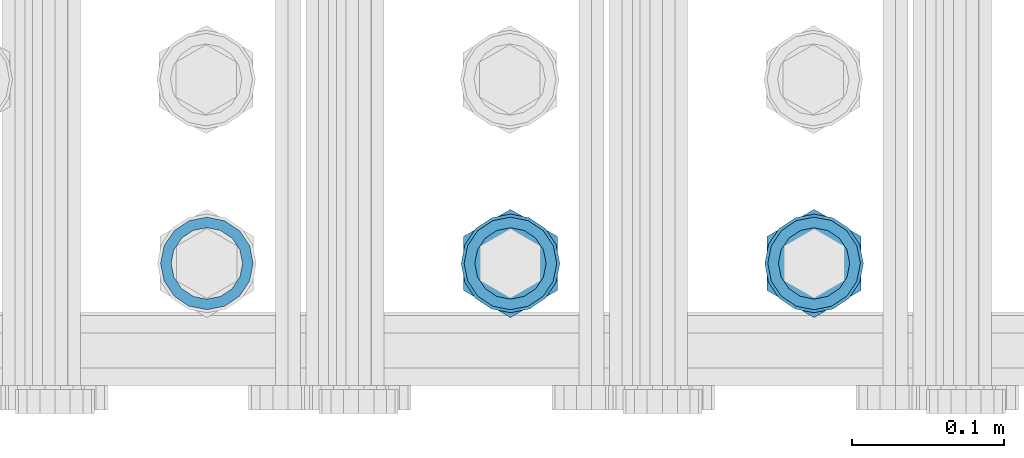
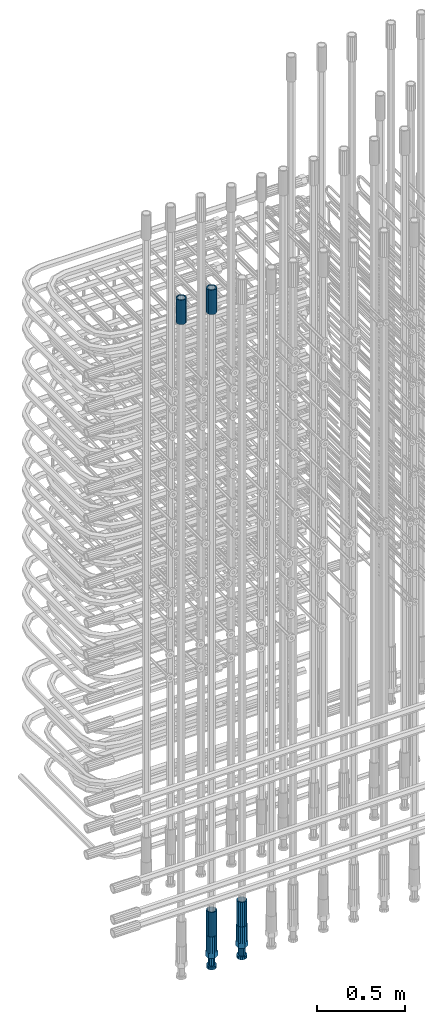
# One storey, part 35 of 177: 6 beams.
"""IFC2X3 building model written with IfcOpenShell, lengths in millimetres."""

from ifc_helpers import new_model, si_unit, frame, origin_with_axes, place, context, subcontext, project, spatial, faceted_brep, material, type_object, element, save


model = new_model("IFC2X3")

# Units and contexts
model_context_1 = context("Model", 3, precision=1e-05, world=origin_with_axes())
model_context_2 = context("Model", 3, precision=1e-05, world=origin_with_axes())
body_context = subcontext(model_context_2, "Body", "Model", "MODEL_VIEW")
ifc_project = project(units=[si_unit("LENGTHUNIT", "METRE", prefix="MILLI"), si_unit("AREAUNIT", "SQUARE_METRE"), si_unit("VOLUMEUNIT", "CUBIC_METRE"), si_unit("MASSUNIT", "GRAM", prefix="KILO"), si_unit("TIMEUNIT", "SECOND"), si_unit("PLANEANGLEUNIT", "RADIAN"), si_unit("SOLIDANGLEUNIT", "STERADIAN"), si_unit("THERMODYNAMICTEMPERATUREUNIT", "DEGREE_CELSIUS"), si_unit("LUMINOUSINTENSITYUNIT", "LUMEN")], contexts=[model_context_1])

# Site, building, storey
site_placement = place(None, origin_with_axes())
site = spatial("IfcSite", under=ifc_project, at=site_placement, CompositionType="ELEMENT")
building_placement = place(site_placement, origin_with_axes())
building = spatial("IfcBuilding", under=site, at=building_placement, Name="Undefined", CompositionType="ELEMENT")
storey_placement = place(building_placement, origin_with_axes())
storey = spatial("IfcBuildingStorey", under=building, at=storey_placement, Name="Undefined", CompositionType="ELEMENT", Elevation=0.0)

# Beams
ifc_material = material(Name="STEEL/S275")
beam_type_1 = type_object("IfcBeamType", PredefinedType="NOTDEFINED")
beam_1_placement = place(storey_placement, frame((2030236.00256267, 6205156.40847529, 22659.9858194828), z_axis=(1.0, 0.0, 0.0), x_axis=(0.0, 0.0, 1.0)))
element("IfcBeam", 1, at=beam_1_placement, inside=storey, type_object=beam_type_1, material=ifc_material, Name="AG40N", context=body_context, shape_type="Brep", body=[
    faceted_brep([(0.0, -23.5000000001164, -9.31322574615479e-10), (0.0, -21.7111690140155, 8.99306066054851), (170.0, -21.7111690140155, 8.99306066054851), (170.0, -23.5, 0.0), (0.0, -16.6170093578839, 16.6170093575493), (170.0, -16.6170093578839, 16.6170093575493), (0.0, -8.99306066057943, 21.7111690137535), (170.0, -8.99306066057943, 21.7111690137535), (0.0, 1.16415321826935e-10, 23.5), (170.0, 0.0, 23.5), (0.0, 8.99306066057943, 21.7111690137535), (170.0, 8.99306066057943, 21.7111690137535), (0.0, 16.6170093578839, 16.6170093575493), (170.0, 16.6170093578839, 16.6170093575493), (0.0, 21.7111690140155, 8.99306066054851), (170.0, 21.7111690140155, 8.99306066054851), (0.0, 23.5000000001164, -9.31322574615479e-10), (170.0, 23.5, 0.0), (0.0, 21.7111690140155, -8.99306066054851), (170.0, 21.7111690140155, -8.99306066054851), (0.0, 16.6170093578839, -16.6170093575493), (170.0, 16.6170093578839, -16.6170093575493), (0.0, 8.99306066057943, -21.7111690137535), (170.0, 8.99306066057943, -21.7111690137535), (0.0, 1.16415321826935e-10, -23.5000000009313), (170.0, 0.0, -23.5), (0.0, -8.99306066057943, -21.7111690137535), (170.0, -8.99306066057943, -21.7111690137535), (0.0, -16.6170093578839, -16.6170093575493), (170.0, -16.6170093578839, -16.6170093575493), (0.0, -21.7111690140155, -8.99306066054851), (170.0, -21.7111690140155, -8.99306066054851), (0.0, -30.5, 0.0), (0.0, -28.1783257415937, -11.6718446873128), (170.0, -28.1783257415937, -11.6718446873128), (170.0, -30.5, 0.0), (0.0, -21.5667568261888, -21.5667568258941), (170.0, -21.5667568261888, -21.5667568258941), (0.0, -11.6718446871346, -28.1783257415518), (170.0, -11.6718446871346, -28.1783257415518), (0.0, 0.0, -30.5), (170.0, 0.0, -30.5), (0.0, 11.6718446871346, -28.1783257415518), (170.0, 11.6718446871346, -28.1783257415518), (0.0, 21.5667568261888, -21.5667568258941), (170.0, 21.5667568261888, -21.5667568258941), (0.0, 28.1783257415937, -11.6718446873128), (170.0, 28.1783257415937, -11.6718446873128), (0.0, 30.5, 0.0), (170.0, 30.5, 0.0), (0.0, 28.1783257415937, 11.6718446873128), (170.0, 28.1783257415937, 11.6718446873128), (0.0, 21.5667568261888, 21.5667568258941), (170.0, 21.5667568261888, 21.5667568258941), (0.0, 11.6718446871346, 28.1783257415518), (170.0, 11.6718446871346, 28.1783257415518), (0.0, 0.0, 30.5), (170.0, 0.0, 30.5), (0.0, -11.6718446871346, 28.1783257415518), (170.0, -11.6718446871346, 28.1783257415518), (0.0, -21.5667568261888, 21.5667568258941), (170.0, -21.5667568261888, 21.5667568258941), (0.0, -28.1783257415937, 11.6718446873128), (170.0, -28.1783257415937, 11.6718446873128)], [[[0, 1, 2, 3]], [[1, 4, 5, 2]], [[4, 6, 7, 5]], [[6, 8, 9, 7]], [[8, 10, 11, 9]], [[10, 12, 13, 11]], [[12, 14, 15, 13]], [[14, 16, 17, 15]], [[16, 18, 19, 17]], [[18, 20, 21, 19]], [[20, 22, 23, 21]], [[22, 24, 25, 23]], [[24, 26, 27, 25]], [[26, 28, 29, 27]], [[28, 30, 31, 29]], [[30, 0, 3, 31]], [[32, 33, 34, 35]], [[33, 36, 37, 34]], [[36, 38, 39, 37]], [[38, 40, 41, 39]], [[40, 42, 43, 41]], [[42, 44, 45, 43]], [[44, 46, 47, 45]], [[46, 48, 49, 47]], [[48, 50, 51, 49]], [[50, 52, 53, 51]], [[52, 54, 55, 53]], [[54, 56, 57, 55]], [[56, 58, 59, 57]], [[58, 60, 61, 59]], [[60, 62, 63, 61]], [[62, 32, 35, 63]], [[37, 39, 41, 43, 45, 47, 49, 51, 53, 55, 57, 59, 61, 63, 35, 34], [5, 7, 9, 11, 13, 15, 17, 19, 21, 23, 25, 27, 29, 31, 3, 2]], [[62, 60, 58, 56, 54, 52, 50, 48, 46, 44, 42, 40, 38, 36, 33, 32], [30, 28, 26, 24, 22, 20, 18, 16, 14, 12, 10, 8, 6, 4, 1, 0]]]),
])
beam_2_placement = place(storey_placement, frame((2030436.00256268, 6205156.4084753, 18490.9668004282), z_axis=(-1.0, 0.0, 0.0), x_axis=(0.0, 0.0, -1.0)))
element("IfcBeam", 2, at=beam_2_placement, inside=storey, type_object=beam_type_1, material=ifc_material, Name="AG40N", context=body_context, shape_type="Brep", body=[
    faceted_brep([(0.0, -23.5000000001164, -9.31322574615479e-10), (0.0, -21.7111690140155, 8.99306066054851), (170.0, -21.7111690140155, 8.99306066054851), (170.0, -23.5, 0.0), (0.0, -16.6170093578839, 16.6170093575493), (170.0, -16.6170093578839, 16.6170093575493), (0.0, -8.99306066057943, 21.7111690137535), (170.0, -8.99306066057943, 21.7111690137535), (0.0, 1.16415321826935e-10, 23.5), (170.0, 0.0, 23.5), (0.0, 8.99306066057943, 21.7111690137535), (170.0, 8.99306066057943, 21.7111690137535), (0.0, 16.6170093578839, 16.6170093575493), (170.0, 16.6170093578839, 16.6170093575493), (0.0, 21.7111690140155, 8.99306066054851), (170.0, 21.7111690140155, 8.99306066054851), (0.0, 23.5000000001164, -9.31322574615479e-10), (170.0, 23.5, 0.0), (0.0, 21.7111690140155, -8.99306066054851), (170.0, 21.7111690140155, -8.99306066054851), (0.0, 16.6170093578839, -16.6170093575493), (170.0, 16.6170093578839, -16.6170093575493), (0.0, 8.99306066057943, -21.7111690137535), (170.0, 8.99306066057943, -21.7111690137535), (0.0, 1.16415321826935e-10, -23.5000000009313), (170.0, 0.0, -23.5), (0.0, -8.99306066057943, -21.7111690137535), (170.0, -8.99306066057943, -21.7111690137535), (0.0, -16.6170093578839, -16.6170093575493), (170.0, -16.6170093578839, -16.6170093575493), (0.0, -21.7111690140155, -8.99306066054851), (170.0, -21.7111690140155, -8.99306066054851), (0.0, -30.5, 0.0), (0.0, -28.1783257415937, -11.6718446873128), (170.0, -28.1783257415937, -11.6718446873128), (170.0, -30.5, 0.0), (0.0, -21.5667568261888, -21.5667568258941), (170.0, -21.5667568261888, -21.5667568258941), (0.0, -11.6718446871346, -28.1783257415518), (170.0, -11.6718446871346, -28.1783257415518), (0.0, 0.0, -30.5), (170.0, 0.0, -30.5), (0.0, 11.6718446871346, -28.1783257415518), (170.0, 11.6718446871346, -28.1783257415518), (0.0, 21.5667568261888, -21.5667568258941), (170.0, 21.5667568261888, -21.5667568258941), (0.0, 28.1783257415937, -11.6718446873128), (170.0, 28.1783257415937, -11.6718446873128), (0.0, 30.5, 0.0), (170.0, 30.5, 0.0), (0.0, 28.1783257415937, 11.6718446873128), (170.0, 28.1783257415937, 11.6718446873128), (0.0, 21.5667568261888, 21.5667568258941), (170.0, 21.5667568261888, 21.5667568258941), (0.0, 11.6718446871346, 28.1783257415518), (170.0, 11.6718446871346, 28.1783257415518), (0.0, 0.0, 30.5), (170.0, 0.0, 30.5), (0.0, -11.6718446871346, 28.1783257415518), (170.0, -11.6718446871346, 28.1783257415518), (0.0, -21.5667568261888, 21.5667568258941), (170.0, -21.5667568261888, 21.5667568258941), (0.0, -28.1783257415937, 11.6718446873128), (170.0, -28.1783257415937, 11.6718446873128)], [[[0, 1, 2, 3]], [[1, 4, 5, 2]], [[4, 6, 7, 5]], [[6, 8, 9, 7]], [[8, 10, 11, 9]], [[10, 12, 13, 11]], [[12, 14, 15, 13]], [[14, 16, 17, 15]], [[16, 18, 19, 17]], [[18, 20, 21, 19]], [[20, 22, 23, 21]], [[22, 24, 25, 23]], [[24, 26, 27, 25]], [[26, 28, 29, 27]], [[28, 30, 31, 29]], [[30, 0, 3, 31]], [[32, 33, 34, 35]], [[33, 36, 37, 34]], [[36, 38, 39, 37]], [[38, 40, 41, 39]], [[40, 42, 43, 41]], [[42, 44, 45, 43]], [[44, 46, 47, 45]], [[46, 48, 49, 47]], [[48, 50, 51, 49]], [[50, 52, 53, 51]], [[52, 54, 55, 53]], [[54, 56, 57, 55]], [[56, 58, 59, 57]], [[58, 60, 61, 59]], [[60, 62, 63, 61]], [[62, 32, 35, 63]], [[37, 39, 41, 43, 45, 47, 49, 51, 53, 55, 57, 59, 61, 63, 35, 34], [5, 7, 9, 11, 13, 15, 17, 19, 21, 23, 25, 27, 29, 31, 3, 2]], [[62, 60, 58, 56, 54, 52, 50, 48, 46, 44, 42, 40, 38, 36, 33, 32], [30, 28, 26, 24, 22, 20, 18, 16, 14, 12, 10, 8, 6, 4, 1, 0]]]),
])
beam_3_placement = place(storey_placement, frame((2030436.00256267, 6205156.40847529, 22659.9858194828), z_axis=(1.0, 0.0, 0.0), x_axis=(0.0, 0.0, 1.0)))
element("IfcBeam", 3, at=beam_3_placement, inside=storey, type_object=beam_type_1, material=ifc_material, Name="AG40N", context=body_context, shape_type="Brep", body=[
    faceted_brep([(0.0, -23.5000000001164, -9.31322574615479e-10), (0.0, -21.7111690140155, 8.99306066054851), (170.0, -21.7111690140155, 8.99306066054851), (170.0, -23.5, 0.0), (0.0, -16.6170093578839, 16.6170093575493), (170.0, -16.6170093578839, 16.6170093575493), (0.0, -8.99306066057943, 21.7111690137535), (170.0, -8.99306066057943, 21.7111690137535), (0.0, 1.16415321826935e-10, 23.5), (170.0, 0.0, 23.5), (0.0, 8.99306066057943, 21.7111690137535), (170.0, 8.99306066057943, 21.7111690137535), (0.0, 16.6170093578839, 16.6170093575493), (170.0, 16.6170093578839, 16.6170093575493), (0.0, 21.7111690140155, 8.99306066054851), (170.0, 21.7111690140155, 8.99306066054851), (0.0, 23.5000000001164, -9.31322574615479e-10), (170.0, 23.5, 0.0), (0.0, 21.7111690140155, -8.99306066054851), (170.0, 21.7111690140155, -8.99306066054851), (0.0, 16.6170093578839, -16.6170093575493), (170.0, 16.6170093578839, -16.6170093575493), (0.0, 8.99306066057943, -21.7111690137535), (170.0, 8.99306066057943, -21.7111690137535), (0.0, 1.16415321826935e-10, -23.5000000009313), (170.0, 0.0, -23.5), (0.0, -8.99306066057943, -21.7111690137535), (170.0, -8.99306066057943, -21.7111690137535), (0.0, -16.6170093578839, -16.6170093575493), (170.0, -16.6170093578839, -16.6170093575493), (0.0, -21.7111690140155, -8.99306066054851), (170.0, -21.7111690140155, -8.99306066054851), (0.0, -30.5, 0.0), (0.0, -28.1783257415937, -11.6718446873128), (170.0, -28.1783257415937, -11.6718446873128), (170.0, -30.5, 0.0), (0.0, -21.5667568261888, -21.5667568258941), (170.0, -21.5667568261888, -21.5667568258941), (0.0, -11.6718446871346, -28.1783257415518), (170.0, -11.6718446871346, -28.1783257415518), (0.0, 0.0, -30.5), (170.0, 0.0, -30.5), (0.0, 11.6718446871346, -28.1783257415518), (170.0, 11.6718446871346, -28.1783257415518), (0.0, 21.5667568261888, -21.5667568258941), (170.0, 21.5667568261888, -21.5667568258941), (0.0, 28.1783257415937, -11.6718446873128), (170.0, 28.1783257415937, -11.6718446873128), (0.0, 30.5, 0.0), (170.0, 30.5, 0.0), (0.0, 28.1783257415937, 11.6718446873128), (170.0, 28.1783257415937, 11.6718446873128), (0.0, 21.5667568261888, 21.5667568258941), (170.0, 21.5667568261888, 21.5667568258941), (0.0, 11.6718446871346, 28.1783257415518), (170.0, 11.6718446871346, 28.1783257415518), (0.0, 0.0, 30.5), (170.0, 0.0, 30.5), (0.0, -11.6718446871346, 28.1783257415518), (170.0, -11.6718446871346, 28.1783257415518), (0.0, -21.5667568261888, 21.5667568258941), (170.0, -21.5667568261888, 21.5667568258941), (0.0, -28.1783257415937, 11.6718446873128), (170.0, -28.1783257415937, 11.6718446873128)], [[[0, 1, 2, 3]], [[1, 4, 5, 2]], [[4, 6, 7, 5]], [[6, 8, 9, 7]], [[8, 10, 11, 9]], [[10, 12, 13, 11]], [[12, 14, 15, 13]], [[14, 16, 17, 15]], [[16, 18, 19, 17]], [[18, 20, 21, 19]], [[20, 22, 23, 21]], [[22, 24, 25, 23]], [[24, 26, 27, 25]], [[26, 28, 29, 27]], [[28, 30, 31, 29]], [[30, 0, 3, 31]], [[32, 33, 34, 35]], [[33, 36, 37, 34]], [[36, 38, 39, 37]], [[38, 40, 41, 39]], [[40, 42, 43, 41]], [[42, 44, 45, 43]], [[44, 46, 47, 45]], [[46, 48, 49, 47]], [[48, 50, 51, 49]], [[50, 52, 53, 51]], [[52, 54, 55, 53]], [[54, 56, 57, 55]], [[56, 58, 59, 57]], [[58, 60, 61, 59]], [[60, 62, 63, 61]], [[62, 32, 35, 63]], [[37, 39, 41, 43, 45, 47, 49, 51, 53, 55, 57, 59, 61, 63, 35, 34], [5, 7, 9, 11, 13, 15, 17, 19, 21, 23, 25, 27, 29, 31, 3, 2]], [[62, 60, 58, 56, 54, 52, 50, 48, 46, 44, 42, 40, 38, 36, 33, 32], [30, 28, 26, 24, 22, 20, 18, 16, 14, 12, 10, 8, 6, 4, 1, 0]]]),
])
beam_4_placement = place(storey_placement, frame((2030636.00256268, 6205156.4084753, 18490.9668004282), z_axis=(-1.0, 0.0, 0.0), x_axis=(0.0, 0.0, -1.0)))
element("IfcBeam", 4, at=beam_4_placement, inside=storey, type_object=beam_type_1, material=ifc_material, Name="AG40N", context=body_context, shape_type="Brep", body=[
    faceted_brep([(0.0, -23.5000000001164, -9.31322574615479e-10), (0.0, -21.7111690140155, 8.99306066054851), (170.0, -21.7111690140155, 8.99306066054851), (170.0, -23.5, 0.0), (0.0, -16.6170093578839, 16.6170093575493), (170.0, -16.6170093578839, 16.6170093575493), (0.0, -8.99306066057943, 21.7111690137535), (170.0, -8.99306066057943, 21.7111690137535), (0.0, 1.16415321826935e-10, 23.5), (170.0, 0.0, 23.5), (0.0, 8.99306066057943, 21.7111690137535), (170.0, 8.99306066057943, 21.7111690137535), (0.0, 16.6170093578839, 16.6170093575493), (170.0, 16.6170093578839, 16.6170093575493), (0.0, 21.7111690140155, 8.99306066054851), (170.0, 21.7111690140155, 8.99306066054851), (0.0, 23.5000000001164, -9.31322574615479e-10), (170.0, 23.5, 0.0), (0.0, 21.7111690140155, -8.99306066054851), (170.0, 21.7111690140155, -8.99306066054851), (0.0, 16.6170093578839, -16.6170093575493), (170.0, 16.6170093578839, -16.6170093575493), (0.0, 8.99306066057943, -21.7111690137535), (170.0, 8.99306066057943, -21.7111690137535), (0.0, 1.16415321826935e-10, -23.5000000009313), (170.0, 0.0, -23.5), (0.0, -8.99306066057943, -21.7111690137535), (170.0, -8.99306066057943, -21.7111690137535), (0.0, -16.6170093578839, -16.6170093575493), (170.0, -16.6170093578839, -16.6170093575493), (0.0, -21.7111690140155, -8.99306066054851), (170.0, -21.7111690140155, -8.99306066054851), (0.0, -30.5, 0.0), (0.0, -28.1783257415937, -11.6718446873128), (170.0, -28.1783257415937, -11.6718446873128), (170.0, -30.5, 0.0), (0.0, -21.5667568261888, -21.5667568258941), (170.0, -21.5667568261888, -21.5667568258941), (0.0, -11.6718446871346, -28.1783257415518), (170.0, -11.6718446871346, -28.1783257415518), (0.0, 0.0, -30.5), (170.0, 0.0, -30.5), (0.0, 11.6718446871346, -28.1783257415518), (170.0, 11.6718446871346, -28.1783257415518), (0.0, 21.5667568261888, -21.5667568258941), (170.0, 21.5667568261888, -21.5667568258941), (0.0, 28.1783257415937, -11.6718446873128), (170.0, 28.1783257415937, -11.6718446873128), (0.0, 30.5, 0.0), (170.0, 30.5, 0.0), (0.0, 28.1783257415937, 11.6718446873128), (170.0, 28.1783257415937, 11.6718446873128), (0.0, 21.5667568261888, 21.5667568258941), (170.0, 21.5667568261888, 21.5667568258941), (0.0, 11.6718446871346, 28.1783257415518), (170.0, 11.6718446871346, 28.1783257415518), (0.0, 0.0, 30.5), (170.0, 0.0, 30.5), (0.0, -11.6718446871346, 28.1783257415518), (170.0, -11.6718446871346, 28.1783257415518), (0.0, -21.5667568261888, 21.5667568258941), (170.0, -21.5667568261888, 21.5667568258941), (0.0, -28.1783257415937, 11.6718446873128), (170.0, -28.1783257415937, 11.6718446873128)], [[[0, 1, 2, 3]], [[1, 4, 5, 2]], [[4, 6, 7, 5]], [[6, 8, 9, 7]], [[8, 10, 11, 9]], [[10, 12, 13, 11]], [[12, 14, 15, 13]], [[14, 16, 17, 15]], [[16, 18, 19, 17]], [[18, 20, 21, 19]], [[20, 22, 23, 21]], [[22, 24, 25, 23]], [[24, 26, 27, 25]], [[26, 28, 29, 27]], [[28, 30, 31, 29]], [[30, 0, 3, 31]], [[32, 33, 34, 35]], [[33, 36, 37, 34]], [[36, 38, 39, 37]], [[38, 40, 41, 39]], [[40, 42, 43, 41]], [[42, 44, 45, 43]], [[44, 46, 47, 45]], [[46, 48, 49, 47]], [[48, 50, 51, 49]], [[50, 52, 53, 51]], [[52, 54, 55, 53]], [[54, 56, 57, 55]], [[56, 58, 59, 57]], [[58, 60, 61, 59]], [[60, 62, 63, 61]], [[62, 32, 35, 63]], [[37, 39, 41, 43, 45, 47, 49, 51, 53, 55, 57, 59, 61, 63, 35, 34], [5, 7, 9, 11, 13, 15, 17, 19, 21, 23, 25, 27, 29, 31, 3, 2]], [[62, 60, 58, 56, 54, 52, 50, 48, 46, 44, 42, 40, 38, 36, 33, 32], [30, 28, 26, 24, 22, 20, 18, 16, 14, 12, 10, 8, 6, 4, 1, 0]]]),
])
beam_type_2 = type_object("IfcBeamType", Name="ROD65", PredefinedType="NOTDEFINED")
beam_5_placement = place(storey_placement, frame((2030436.00256267, 6205156.4084753, 18320.9668004282), z_axis=(-1.0, 0.0, 0.0), x_axis=(0.0, 0.0, -1.0)))
element("IfcBeam", 5, at=beam_5_placement, inside=storey, type_object=beam_type_2, material=ifc_material, Name="AGB40", ObjectType="ROD65", context=body_context, shape_type="Brep", body=[
    faceted_brep([(117.0, 8.17543110251427, 30.873805644922), (117.0, 17.8250000001863, 30.873805644922), (117.0, 22.0056958701462, 23.6326279877685), (117.0, 12.4372115517035, 30.0260848065373), (117.0, -17.8250000001863, 30.873805644922), (150.200000000186, -17.8250000001863, 30.873805644922), (150.200000000186, 17.8250000001863, 30.873805644922), (117.0, -8.17543110251427, 30.873805644922), (117.0, -12.4372115517035, 30.0260848065373), (117.0, -22.0056958701462, 23.6326279877685), (117.0, -35.6500000003725, 0.0), (150.200000000186, -35.6500000003725, 0.0), (117.0, -30.8443150008097, 8.32369058486074), (117.0, -32.5, 0.0), (117.0, -30.8443150008097, -8.32369058462791), (117.0, -17.8250000001863, -30.873805644922), (150.200000000186, -17.8250000001863, -30.873805644922), (117.0, -22.0056958701462, -23.6326279877685), (117.0, -12.4372115517035, -30.0260848065373), (117.0, -8.17543110251427, -30.873805644922), (117.0, 17.8250000001863, -30.873805644922), (150.200000000186, 17.8250000001863, -30.873805644922), (117.0, 8.17543110251427, -30.873805644922), (117.0, 22.0056958701462, -23.6326279877685), (117.0, 12.4372115517035, -30.0260848065373), (117.0, 35.6500000003725, 0.0), (150.200000000186, 35.6500000003725, 0.0), (117.0, 30.8443150008097, -8.32369058486074), (117.0, 30.8443150008097, 8.32369058462791), (117.0, 32.5, 0.0), (0.0, -22.9809703892097, 22.9809703885621), (0.0, -30.0260848058388, 12.4372115518636), (117.0, -30.0260848067701, 12.4372115519363), (117.0, -22.9809703882784, 22.9809703885112), (-2.3283064365387e-10, 22.9809703892097, -22.9809703885639), (-4.65661287307739e-10, 30.0260848077014, -12.4372115518672), (117.0, 30.0260848067701, -12.4372115519363), (117.0, 22.9809703882784, -22.9809703885112), (-2.3283064365387e-10, -30.0260848067701, -12.4372115518672), (-2.3283064365387e-10, -22.9809703892097, -22.9809703885621), (117.0, -22.9809703882784, -22.9809703885112), (117.0, -30.0260848067701, -12.4372115519363), (-2.3283064365387e-10, -12.4372115507722, 30.0260848066137), (-2.3283064365387e-10, 9.31322574615479e-10, 32.4999999999982), (-2.3283064365387e-10, 12.4372115526348, 30.0260848066137), (0.0, 22.9809703892097, 22.9809703885621), (-2.3283064365387e-10, 30.0260848077014, 12.4372115518636), (-2.3283064365387e-10, 32.5, 0.0), (-2.3283064365387e-10, 12.4372115526348, -30.0260848066173), (-2.3283064365387e-10, 9.31322574615479e-10, -32.5), (-2.3283064365387e-10, -12.4372115517035, -30.0260848066173), (-4.65661287307739e-10, -32.4999999990687, -1.81898940354586e-12), (117.0, 22.9809703882784, 22.9809703885112), (117.0, 30.0260848067701, 12.4372115519363), (117.0, 0.0, -32.5), (117.0, 0.0, 32.5), (150.200000000186, 10.5, -18.1865334794857), (150.200000000186, 0.0, -21.0), (150.200000000186, -10.5, -18.1865334794857), (150.200000000186, -18.18653347902, -10.5), (150.200000000186, -21.0, 0.0), (150.200000000186, -18.18653347902, 10.5), (150.200000000186, -10.5, 18.1865334794857), (150.200000000186, 0.0, 21.0), (150.200000000186, 10.5, 18.1865334794857), (150.200000000186, 18.18653347902, 10.5), (150.200000000186, 21.0, 0.0), (150.200000000186, 18.18653347902, -10.5), (210.980000000447, -10.5, -18.1865334794857), (210.980000000447, 0.0, -21.0), (210.980000000447, -18.18653347902, -10.5), (210.980000000447, -21.0, 0.0), (210.980000000447, -18.18653347902, 10.5), (210.980000000447, -10.5, 18.1865334794857), (210.980000000447, 0.0, 21.0), (210.980000000447, 10.5, 18.1865334794857), (210.980000000447, 18.18653347902, 10.5), (210.980000000447, 21.0, 0.0), (210.980000000447, 18.18653347902, -10.5), (210.980000000447, 10.5, -18.1865334794857), (211.001368442696, -27.7269937992096, -11.491116326768), (211.003082550167, -21.2238094303757, -21.223815418547), (231.002518367059, -21.2131944671273, -21.2132004550658), (231.000804259587, -27.7163788359612, -11.4805013632867), (211.001368440451, -11.4911085031927, -27.7269970395137), (231.000804257343, -11.4804935399443, -27.7163820760325), (210.996487071217, -0.0106065049767494, -30.0106107392348), (230.995922888109, 8.45827162265778e-06, -29.9999957757536), (210.989181586672, 11.46989420522, -27.7269970329944), (230.988617403564, 11.4805091684684, -27.7163820695132), (210.980564180623, 21.2025914648548, -21.2238154064398), (230.979999997515, 21.2132064281031, -21.2132004429586), (210.971946775022, 27.7057703435421, -11.4911163107026), (230.971382591913, 27.7163853067905, -11.4805013472214), (210.96464129175, 29.9893808094785, -0.0106149562634528), (230.964077108642, 29.9999957727268, 7.21774995326996e-09), (210.959759924415, 27.7057638689876, 11.4698863970116), (230.959195741307, 27.7163788322359, 11.4805013604928), (210.958045816944, 21.2025795001537, 21.2025854887906), (230.957481633835, 21.213194463402, 21.2132004522718), (210.95975992666, 11.4698785729706, 27.7057671097573), (230.959195743551, 11.480493536219, 27.7163820732385), (210.964641295894, -0.010623425245285, 29.9893808094785), (230.964077112785, -8.46199691295624e-06, 29.9999957729597), (210.971946780439, -11.4911241354421, 27.705767103238), (230.97138259733, -11.4805091721937, 27.7163820667192), (210.980564186488, -21.2238213950768, 21.2025854766835), (230.980000003379, -21.2132064318284, 21.2132004401647), (210.989181592089, -27.7270002737641, 11.4698863809463), (230.988617408981, -27.7163853105158, 11.4805013444275), (210.996487075361, -30.0106107397005, -0.0106149734929204), (230.995922892253, -29.9999957764521, -1.00117176771164e-08)], [[[0, 1, 2, 3]], [[4, 5, 6, 1, 0, 7]], [[4, 7, 8, 9]], [[10, 11, 5, 4, 9, 12]], [[10, 12, 13, 14]], [[15, 16, 11, 10, 14, 17]], [[15, 17, 18, 19]], [[20, 21, 16, 15, 19, 22]], [[23, 20, 22, 24]], [[25, 26, 21, 20, 23, 27]], [[28, 25, 27, 29]], [[30, 31, 32, 33]], [[34, 35, 36, 37]], [[38, 39, 40, 41]], [[31, 30, 42, 43, 44, 45, 46, 47, 35, 34, 48, 49, 50, 39, 38, 51]], [[46, 45, 52, 53]], [[29, 47, 46, 53, 28]], [[27, 36, 35, 47, 29]], [[23, 37, 36, 27]], [[24, 48, 34, 37, 23]], [[22, 54, 49, 48, 24]], [[19, 54, 22]], [[18, 50, 49, 54, 19]], [[17, 40, 39, 50, 18]], [[14, 41, 40, 17]], [[13, 51, 38, 41, 14]], [[12, 32, 31, 51, 13]], [[9, 33, 32, 12]], [[8, 42, 30, 33, 9]], [[7, 55, 43, 42, 8]], [[0, 55, 7]], [[3, 44, 43, 55, 0]], [[2, 52, 45, 44, 3]], [[28, 53, 52, 2]], [[1, 6, 26, 25, 28, 2]], [[5, 11, 16, 21, 26, 6], [56, 57, 58, 59, 60, 61, 62, 63, 64, 65, 66, 67]], [[68, 58, 57, 69]], [[70, 59, 58, 68]], [[71, 60, 59, 70]], [[72, 61, 60, 71]], [[73, 62, 61, 72]], [[74, 63, 62, 73]], [[75, 64, 63, 74]], [[76, 65, 64, 75]], [[77, 66, 65, 76]], [[78, 67, 66, 77]], [[79, 56, 67, 78]], [[69, 57, 56, 79]], [[80, 81, 82, 83]], [[81, 84, 85, 82]], [[84, 86, 87, 85]], [[86, 88, 89, 87]], [[88, 90, 91, 89]], [[90, 92, 93, 91]], [[92, 94, 95, 93]], [[94, 96, 97, 95]], [[96, 98, 99, 97]], [[98, 100, 101, 99]], [[100, 102, 103, 101]], [[102, 104, 105, 103]], [[104, 106, 107, 105]], [[106, 108, 109, 107]], [[108, 110, 111, 109]], [[82, 85, 87, 89, 91, 93, 95, 97, 99, 101, 103, 105, 107, 109, 111, 83]], [[110, 80, 83, 111]], [[108, 106, 104, 102, 100, 98, 96, 94, 92, 90, 88, 86, 84, 81, 80, 110], [78, 77, 76, 75, 74, 73, 72, 71, 70, 68, 69, 79]]]),
])
beam_6_placement = place(storey_placement, frame((2030636.00256267, 6205156.4084753, 18320.9668004282), z_axis=(-1.0, 0.0, 0.0), x_axis=(0.0, 0.0, -1.0)))
element("IfcBeam", 6, at=beam_6_placement, inside=storey, type_object=beam_type_2, material=ifc_material, Name="AGB40", ObjectType="ROD65", context=body_context, shape_type="Brep", body=[
    faceted_brep([(117.0, 8.17543110251427, 30.873805644922), (117.0, 17.8250000001863, 30.873805644922), (117.0, 22.0056958701462, 23.6326279877685), (117.0, 12.4372115517035, 30.0260848065373), (117.0, -17.8250000001863, 30.873805644922), (150.200000000186, -17.8250000001863, 30.873805644922), (150.200000000186, 17.8250000001863, 30.873805644922), (117.0, -8.17543110251427, 30.873805644922), (117.0, -12.4372115517035, 30.0260848065373), (117.0, -22.0056958701462, 23.6326279877685), (117.0, -35.6500000003725, 0.0), (150.200000000186, -35.6500000003725, 0.0), (117.0, -30.8443150008097, 8.32369058486074), (117.0, -32.5, 0.0), (117.0, -30.8443150008097, -8.32369058462791), (117.0, -17.8250000001863, -30.873805644922), (150.200000000186, -17.8250000001863, -30.873805644922), (117.0, -22.0056958701462, -23.6326279877685), (117.0, -12.4372115517035, -30.0260848065373), (117.0, -8.17543110251427, -30.873805644922), (117.0, 17.8250000001863, -30.873805644922), (150.200000000186, 17.8250000001863, -30.873805644922), (117.0, 8.17543110251427, -30.873805644922), (117.0, 22.0056958701462, -23.6326279877685), (117.0, 12.4372115517035, -30.0260848065373), (117.0, 35.6500000003725, 0.0), (150.200000000186, 35.6500000003725, 0.0), (117.0, 30.8443150008097, -8.32369058486074), (117.0, 30.8443150008097, 8.32369058462791), (117.0, 32.5, 0.0), (0.0, -22.9809703892097, 22.9809703885621), (0.0, -30.0260848058388, 12.4372115518636), (117.0, -30.0260848067701, 12.4372115519363), (117.0, -22.9809703882784, 22.9809703885112), (-2.3283064365387e-10, 22.9809703892097, -22.9809703885639), (-4.65661287307739e-10, 30.0260848077014, -12.4372115518672), (117.0, 30.0260848067701, -12.4372115519363), (117.0, 22.9809703882784, -22.9809703885112), (-2.3283064365387e-10, -30.0260848067701, -12.4372115518672), (-2.3283064365387e-10, -22.9809703892097, -22.9809703885621), (117.0, -22.9809703882784, -22.9809703885112), (117.0, -30.0260848067701, -12.4372115519363), (-2.3283064365387e-10, -12.4372115507722, 30.0260848066137), (-2.3283064365387e-10, 9.31322574615479e-10, 32.4999999999982), (-2.3283064365387e-10, 12.4372115526348, 30.0260848066137), (0.0, 22.9809703892097, 22.9809703885621), (-2.3283064365387e-10, 30.0260848077014, 12.4372115518636), (-2.3283064365387e-10, 32.5, 0.0), (-2.3283064365387e-10, 12.4372115526348, -30.0260848066173), (-2.3283064365387e-10, 9.31322574615479e-10, -32.5), (-2.3283064365387e-10, -12.4372115517035, -30.0260848066173), (-4.65661287307739e-10, -32.4999999990687, -1.81898940354586e-12), (117.0, 22.9809703882784, 22.9809703885112), (117.0, 30.0260848067701, 12.4372115519363), (117.0, 0.0, -32.5), (117.0, 0.0, 32.5), (150.200000000186, 10.5, -18.1865334794857), (150.200000000186, 0.0, -21.0), (150.200000000186, -10.5, -18.1865334794857), (150.200000000186, -18.18653347902, -10.5), (150.200000000186, -21.0, 0.0), (150.200000000186, -18.18653347902, 10.5), (150.200000000186, -10.5, 18.1865334794857), (150.200000000186, 0.0, 21.0), (150.200000000186, 10.5, 18.1865334794857), (150.200000000186, 18.18653347902, 10.5), (150.200000000186, 21.0, 0.0), (150.200000000186, 18.18653347902, -10.5), (210.980000000447, -10.5, -18.1865334794857), (210.980000000447, 0.0, -21.0), (210.980000000447, -18.18653347902, -10.5), (210.980000000447, -21.0, 0.0), (210.980000000447, -18.18653347902, 10.5), (210.980000000447, -10.5, 18.1865334794857), (210.980000000447, 0.0, 21.0), (210.980000000447, 10.5, 18.1865334794857), (210.980000000447, 18.18653347902, 10.5), (210.980000000447, 21.0, 0.0), (210.980000000447, 18.18653347902, -10.5), (210.980000000447, 10.5, -18.1865334794857), (211.001368442696, -27.7269937992096, -11.491116326768), (211.003082550167, -21.2238094303757, -21.223815418547), (231.002518367059, -21.2131944671273, -21.2132004550658), (231.000804259587, -27.7163788359612, -11.4805013632867), (211.001368440451, -11.4911085031927, -27.7269970395137), (231.000804257343, -11.4804935399443, -27.7163820760325), (210.996487071217, -0.0106065049767494, -30.0106107392348), (230.995922888109, 8.45827162265778e-06, -29.9999957757536), (210.989181586672, 11.46989420522, -27.7269970329944), (230.988617403564, 11.4805091684684, -27.7163820695132), (210.980564180623, 21.2025914648548, -21.2238154064398), (230.979999997515, 21.2132064281031, -21.2132004429586), (210.971946775022, 27.7057703435421, -11.4911163107026), (230.971382591913, 27.7163853067905, -11.4805013472214), (210.96464129175, 29.9893808094785, -0.0106149562634528), (230.964077108642, 29.9999957727268, 7.21774995326996e-09), (210.959759924415, 27.7057638689876, 11.4698863970116), (230.959195741307, 27.7163788322359, 11.4805013604928), (210.958045816944, 21.2025795001537, 21.2025854887906), (230.957481633835, 21.213194463402, 21.2132004522718), (210.95975992666, 11.4698785729706, 27.7057671097573), (230.959195743551, 11.480493536219, 27.7163820732385), (210.964641295894, -0.010623425245285, 29.9893808094785), (230.964077112785, -8.46199691295624e-06, 29.9999957729597), (210.971946780439, -11.4911241354421, 27.705767103238), (230.97138259733, -11.4805091721937, 27.7163820667192), (210.980564186488, -21.2238213950768, 21.2025854766835), (230.980000003379, -21.2132064318284, 21.2132004401647), (210.989181592089, -27.7270002737641, 11.4698863809463), (230.988617408981, -27.7163853105158, 11.4805013444275), (210.996487075361, -30.0106107397005, -0.0106149734929204), (230.995922892253, -29.9999957764521, -1.00117176771164e-08)], [[[0, 1, 2, 3]], [[4, 5, 6, 1, 0, 7]], [[4, 7, 8, 9]], [[10, 11, 5, 4, 9, 12]], [[10, 12, 13, 14]], [[15, 16, 11, 10, 14, 17]], [[15, 17, 18, 19]], [[20, 21, 16, 15, 19, 22]], [[23, 20, 22, 24]], [[25, 26, 21, 20, 23, 27]], [[28, 25, 27, 29]], [[30, 31, 32, 33]], [[34, 35, 36, 37]], [[38, 39, 40, 41]], [[31, 30, 42, 43, 44, 45, 46, 47, 35, 34, 48, 49, 50, 39, 38, 51]], [[46, 45, 52, 53]], [[29, 47, 46, 53, 28]], [[27, 36, 35, 47, 29]], [[23, 37, 36, 27]], [[24, 48, 34, 37, 23]], [[22, 54, 49, 48, 24]], [[19, 54, 22]], [[18, 50, 49, 54, 19]], [[17, 40, 39, 50, 18]], [[14, 41, 40, 17]], [[13, 51, 38, 41, 14]], [[12, 32, 31, 51, 13]], [[9, 33, 32, 12]], [[8, 42, 30, 33, 9]], [[7, 55, 43, 42, 8]], [[0, 55, 7]], [[3, 44, 43, 55, 0]], [[2, 52, 45, 44, 3]], [[28, 53, 52, 2]], [[1, 6, 26, 25, 28, 2]], [[5, 11, 16, 21, 26, 6], [56, 57, 58, 59, 60, 61, 62, 63, 64, 65, 66, 67]], [[68, 58, 57, 69]], [[70, 59, 58, 68]], [[71, 60, 59, 70]], [[72, 61, 60, 71]], [[73, 62, 61, 72]], [[74, 63, 62, 73]], [[75, 64, 63, 74]], [[76, 65, 64, 75]], [[77, 66, 65, 76]], [[78, 67, 66, 77]], [[79, 56, 67, 78]], [[69, 57, 56, 79]], [[80, 81, 82, 83]], [[81, 84, 85, 82]], [[84, 86, 87, 85]], [[86, 88, 89, 87]], [[88, 90, 91, 89]], [[90, 92, 93, 91]], [[92, 94, 95, 93]], [[94, 96, 97, 95]], [[96, 98, 99, 97]], [[98, 100, 101, 99]], [[100, 102, 103, 101]], [[102, 104, 105, 103]], [[104, 106, 107, 105]], [[106, 108, 109, 107]], [[108, 110, 111, 109]], [[82, 85, 87, 89, 91, 93, 95, 97, 99, 101, 103, 105, 107, 109, 111, 83]], [[110, 80, 83, 111]], [[108, 106, 104, 102, 100, 98, 96, 94, 92, 90, 88, 86, 84, 81, 80, 110], [78, 77, 76, 75, 74, 73, 72, 71, 70, 68, 69, 79]]]),
])

save(model, "model.ifc")
